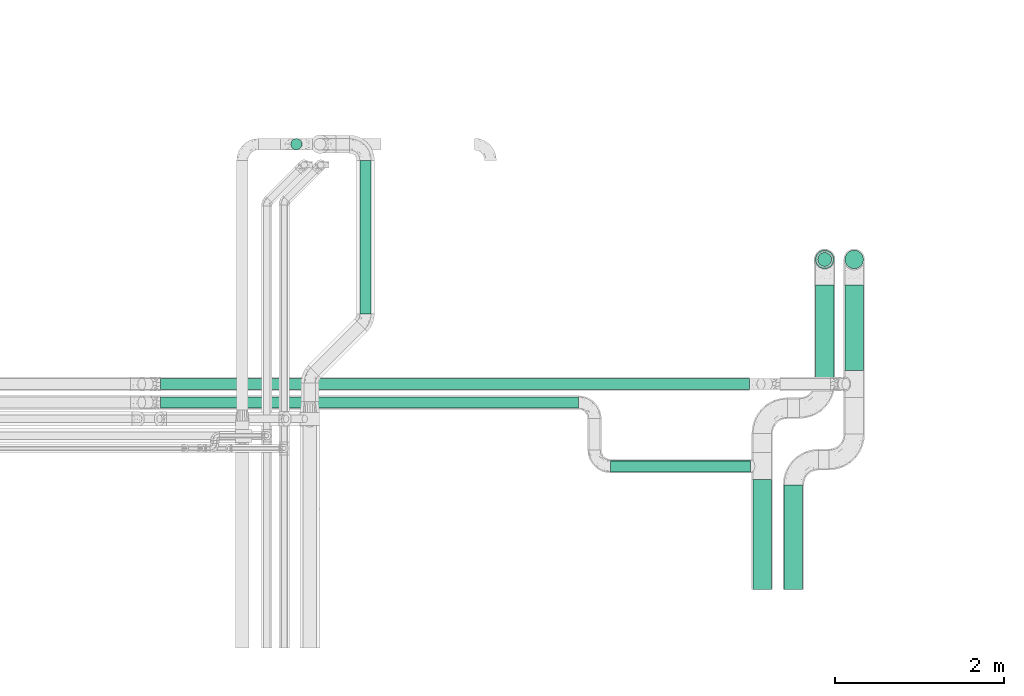
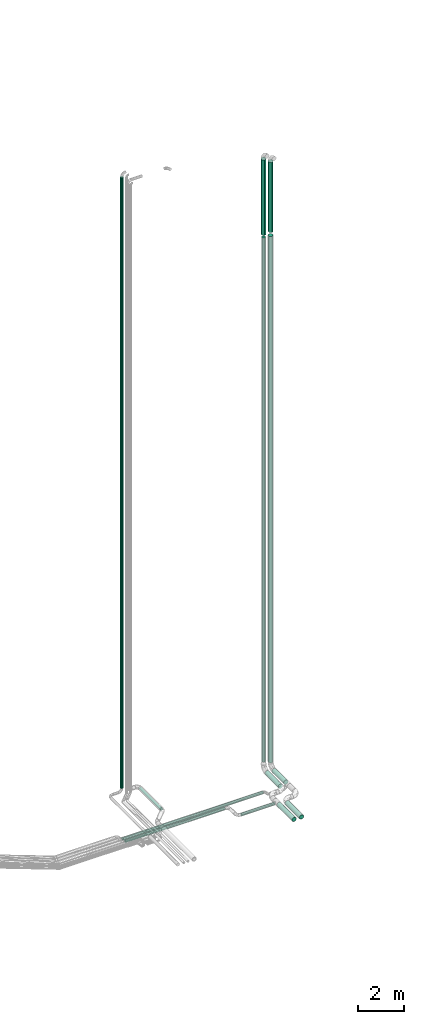
# One storey, part 46 of 93: 13 flow segments.
"""IFC2X3 building model written with IfcOpenShell, lengths in millimetres."""

from ifc_helpers import new_model, entity, si_unit, converted_unit, derived_unit, direction, frame, origin, origin_2d_with_axis, place, context, subcontext, project, spatial, circle, extrude, type_object, element, save


model = new_model("IFC2X3")

# Units and contexts
model_context = context("Model", 3, precision=0.01, world=origin(), true_north=direction((6.12303176911189e-17, 1.0)))
body_context = subcontext(model_context, "Body", "Model", "MODEL_VIEW")
ifc_project = project(units=[si_unit("LENGTHUNIT", "METRE", prefix="MILLI"), si_unit("AREAUNIT", "SQUARE_METRE"), si_unit("VOLUMEUNIT", "CUBIC_METRE"), converted_unit("PLANEANGLEUNIT", "DEGREE", entity("IfcRatioMeasure", 0.0174532925199433), si_unit("PLANEANGLEUNIT", "RADIAN"), dimensions=[0, 0, 0, 0, 0, 0, 0]), si_unit("MASSUNIT", "GRAM", prefix="KILO"), derived_unit("MASSDENSITYUNIT", [(si_unit("MASSUNIT", "GRAM", prefix="KILO"), 1), (si_unit("LENGTHUNIT", "METRE"), -3)]), derived_unit("MOMENTOFINERTIAUNIT", [(si_unit("LENGTHUNIT", "METRE"), 4)]), si_unit("TIMEUNIT", "SECOND"), si_unit("FREQUENCYUNIT", "HERTZ"), si_unit("THERMODYNAMICTEMPERATUREUNIT", "DEGREE_CELSIUS"), derived_unit("THERMALTRANSMITTANCEUNIT", [(si_unit("MASSUNIT", "GRAM", prefix="KILO"), 1), (si_unit("THERMODYNAMICTEMPERATUREUNIT", "KELVIN"), -1), (si_unit("TIMEUNIT", "SECOND"), -3)]), derived_unit("VOLUMETRICFLOWRATEUNIT", [(si_unit("LENGTHUNIT", "METRE"), 3), (si_unit("TIMEUNIT", "SECOND"), -1)]), derived_unit("MASSFLOWRATEUNIT", [(si_unit("MASSUNIT", "GRAM", prefix="KILO"), 1), (si_unit("TIMEUNIT", "SECOND"), -1)]), derived_unit("ROTATIONALFREQUENCYUNIT", [(si_unit("TIMEUNIT", "SECOND"), -1)]), si_unit("ELECTRICCURRENTUNIT", "AMPERE"), si_unit("ELECTRICVOLTAGEUNIT", "VOLT"), si_unit("POWERUNIT", "WATT"), si_unit("FORCEUNIT", "NEWTON", prefix="KILO"), si_unit("ILLUMINANCEUNIT", "LUX"), si_unit("LUMINOUSFLUXUNIT", "LUMEN"), si_unit("LUMINOUSINTENSITYUNIT", "CANDELA"), derived_unit("USERDEFINED", [(si_unit("MASSUNIT", "GRAM", prefix="KILO"), -1), (si_unit("LENGTHUNIT", "METRE"), -2), (si_unit("TIMEUNIT", "SECOND"), 3), (si_unit("LUMINOUSFLUXUNIT", "LUMEN"), 1)]), derived_unit("LINEARVELOCITYUNIT", [(si_unit("LENGTHUNIT", "METRE"), 1), (si_unit("TIMEUNIT", "SECOND"), -1)]), si_unit("PRESSUREUNIT", "PASCAL"), derived_unit("USERDEFINED", [(si_unit("LENGTHUNIT", "METRE"), -2), (si_unit("MASSUNIT", "GRAM", prefix="KILO"), 1), (si_unit("TIMEUNIT", "SECOND"), -2)]), derived_unit("LINEARFORCEUNIT", [(si_unit("MASSUNIT", "GRAM", prefix="KILO"), 1), (si_unit("LENGTHUNIT", "METRE"), 1), (si_unit("TIMEUNIT", "SECOND"), -2), (si_unit("LENGTHUNIT", "METRE"), -1)]), derived_unit("PLANARFORCEUNIT", [(si_unit("MASSUNIT", "GRAM", prefix="KILO"), 1), (si_unit("LENGTHUNIT", "METRE"), 1), (si_unit("TIMEUNIT", "SECOND"), -2), (si_unit("LENGTHUNIT", "METRE"), -2)])], contexts=[model_context])

# Site, building, storey
site_placement = place(None, origin())
site = spatial("IfcSite", under=ifc_project, at=site_placement, CompositionType="ELEMENT")
building_placement = place(site_placement, origin())
building = spatial("IfcBuilding", under=site, at=building_placement, CompositionType="ELEMENT")
storey_placement = place(building_placement, frame((0.0, 0.0, -4200.0)))
storey = spatial("IfcBuildingStorey", under=building, at=storey_placement, CompositionType="ELEMENT", Elevation=-4200.0)

# Flow segments
pipe_segment_type_1 = type_object("IfcPipeSegmentType", PredefinedType="NOTDEFINED")
flow_segment_1_placement = place(storey_placement, frame((30598.69, 7038.76, 2688.9)))
element("IfcFlowSegment", 1, at=flow_segment_1_placement, inside=storey, type_object=pipe_segment_type_1, context=body_context, shape_type="SweptSolid", body=[
    extrude(circle(Radius=109.5, at=origin_2d_with_axis()), frame((111.1, 0.0, 111.1), z_axis=(0.0, 1.0, 0.0), x_axis=(1.0, 0.0, 0.0)), (0.0, 0.0, 1.0), 1239.99999999999),
])
flow_segment_2_placement = place(storey_placement, frame((31318.9, 9634.14, 2688.9)))
element("IfcFlowSegment", 2, at=flow_segment_2_placement, inside=storey, type_object=pipe_segment_type_1, context=body_context, shape_type="SweptSolid", body=[
    extrude(circle(Radius=109.5, at=origin_2d_with_axis()), frame((111.1, 0.0, 111.1), z_axis=(0.0, 1.0, 0.0), x_axis=(1.0, 0.0, 0.0)), (0.0, 0.0, 1.0), 1015.8612780823),
])
flow_segment_3_placement = place(storey_placement, frame((30968.9, 9488.76, 2688.9)))
element("IfcFlowSegment", 3, at=flow_segment_3_placement, inside=storey, type_object=pipe_segment_type_1, context=body_context, shape_type="SweptSolid", body=[
    extrude(circle(Radius=109.5, at=origin_2d_with_axis()), frame((111.1, 0.0, 111.1), z_axis=(0.0, 1.0, 0.0), x_axis=(1.0, 0.0, 0.0)), (0.0, 0.0, 1.0), 1161.23991781962),
])
flow_segment_4_placement = place(storey_placement, frame((30228.69, 7038.76, 2688.9)))
element("IfcFlowSegment", 4, at=flow_segment_4_placement, inside=storey, type_object=pipe_segment_type_1, context=body_context, shape_type="SweptSolid", body=[
    extrude(circle(Radius=109.5, at=origin_2d_with_axis()), frame((111.1, 0.0, 111.1), z_axis=(0.0, 1.0, 0.0), x_axis=(1.0, 0.0, 0.0)), (0.0, 0.0, 1.0), 1301.23958365229),
])
flow_segment_5_placement = place(storey_placement, frame((30968.9, 10838.9, 30937.5)))
element("IfcFlowSegment", 5, at=flow_segment_5_placement, inside=storey, type_object=pipe_segment_type_1, context=body_context, shape_type="SweptSolid", body=[
    extrude(circle(Radius=109.5, at=origin_2d_with_axis()), frame((111.1, 111.1, 0.0), z_axis=(-9.8899554591556e-08, 0.0, 1.0), x_axis=(-1.0, 0.0, -9.8899554591556e-08)), (0.0, 0.0, 1.0), 3962.49578621979),
])
flow_segment_6_placement = place(storey_placement, frame((25571.03, 10304.27, 2931.9)))
element("IfcFlowSegment", 6, at=flow_segment_6_placement, inside=storey, type_object=pipe_segment_type_1, context=body_context, shape_type="SweptSolid", body=[
    extrude(circle(Radius=66.5, at=origin_2d_with_axis()), frame((68.1, 0.0, 68.1), z_axis=(0.0, 1.0, 0.0), x_axis=(1.0, 0.0, 0.0)), (0.0, 0.0, 1.0), 1821.29942314912),
])
flow_segment_7_placement = place(storey_placement, frame((24751.2, 12247.47, 3190.76)))
element("IfcFlowSegment", 7, at=flow_segment_7_placement, inside=storey, type_object=pipe_segment_type_1, context=body_context, shape_type="SweptSolid", body=[
    extrude(circle(Radius=66.5, at=origin_2d_with_axis()), frame((68.1, 68.1, 0.0), z_axis=(0.0, 0.0, 1.0), x_axis=(-1.0, 0.0, 0.0)), (0.0, 0.0, 1.0), 32119.2428396925),
])
flow_segment_8_placement = place(storey_placement, frame((31318.9, 10838.9, 30962.5)))
element("IfcFlowSegment", 8, at=flow_segment_8_placement, inside=storey, type_object=pipe_segment_type_1, context=body_context, shape_type="SweptSolid", body=[
    extrude(circle(Radius=109.5, at=origin_2d_with_axis()), frame((111.1, 111.1, 0.0), z_axis=(0.0, 0.0, 1.0), x_axis=(-1.0, 0.0, 0.0)), (0.0, 0.0, 1.0), 3687.50000000001),
])
flow_segment_9_placement = place(storey_placement, frame((31318.9, 10838.9, 3100.0)))
element("IfcFlowSegment", 9, at=flow_segment_9_placement, inside=storey, type_object=pipe_segment_type_1, context=body_context, shape_type="SweptSolid", body=[
    extrude(circle(Radius=109.5, at=origin_2d_with_axis()), frame((111.1, 111.1, 0.0), z_axis=(0.0, 0.0, 1.0), x_axis=(-1.0, 0.0, 0.0)), (0.0, 0.0, 1.0), 27657.5),
])
flow_segment_10_placement = place(storey_placement, frame((23210.57, 9406.04, 2731.9)))
element("IfcFlowSegment", 10, at=flow_segment_10_placement, inside=storey, type_object=pipe_segment_type_1, context=body_context, shape_type="SweptSolid", body=[
    extrude(circle(Radius=66.5, at=origin_2d_with_axis()), frame((0.0, 68.1, 68.1), z_axis=(1.0, 0.0, 0.0), x_axis=(0.0, -1.0, 0.0)), (0.0, 0.0, 1.0), 6980.73067498007),
])
flow_segment_11_placement = place(storey_placement, frame((23210.57, 9186.64, 2731.9)))
element("IfcFlowSegment", 11, at=flow_segment_11_placement, inside=storey, type_object=pipe_segment_type_1, context=body_context, shape_type="SweptSolid", body=[
    extrude(circle(Radius=66.5, at=origin_2d_with_axis()), frame((0.0, 68.1, 68.1), z_axis=(1.0, 0.0, 0.0), x_axis=(0.0, 1.0, 0.0)), (0.0, 0.0, 1.0), 4952.83139254912),
])
flow_segment_12_placement = place(storey_placement, frame((28543.4, 8431.9, 2731.9)))
element("IfcFlowSegment", 12, at=flow_segment_12_placement, inside=storey, type_object=pipe_segment_type_1, context=body_context, shape_type="SweptSolid", body=[
    extrude(circle(Radius=66.5, at=origin_2d_with_axis()), frame((0.0, 68.1, 68.1), z_axis=(1.0, 0.0, 0.0), x_axis=(0.0, -1.0, 0.0)), (0.0, 0.0, 1.0), 1656.38155763209),
])
pipe_segment_type_2 = type_object("IfcPipeSegmentType", PredefinedType="NOTDEFINED")
flow_segment_13_placement = place(storey_placement, frame((30995.9, 10865.9, 3240.0)))
element("IfcFlowSegment", 13, at=flow_segment_13_placement, inside=storey, type_object=pipe_segment_type_2, context=body_context, shape_type="SweptSolid", body=[
    extrude(circle(Radius=82.5, at=origin_2d_with_axis()), frame((84.1, 84.1, 0.0), z_axis=(0.0, 0.0, 1.0), x_axis=(-1.0, 0.0, 0.0)), (0.0, 0.0, 1.0), 27542.5),
])

save(model, "model.ifc")
